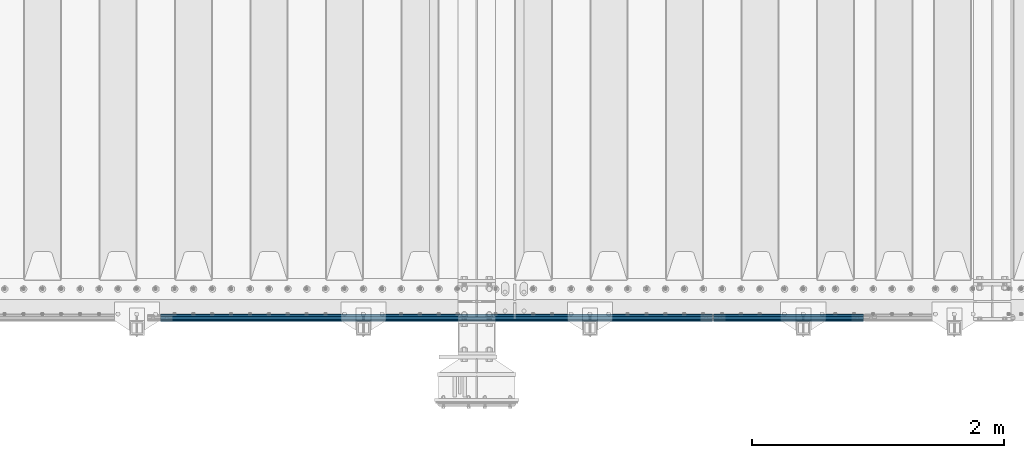
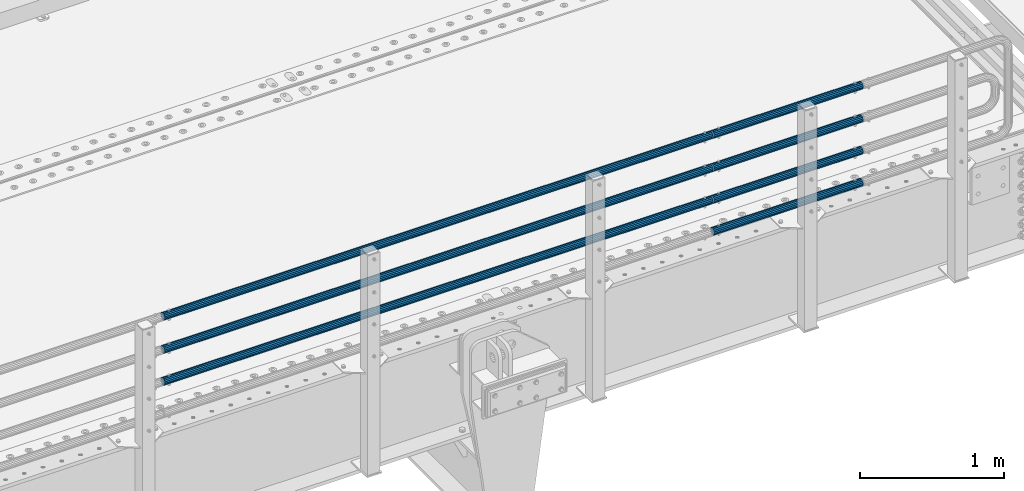
# One storey, part 100 of 208: 7 beams.
"""IFC2X3 building model written with IfcOpenShell, lengths in millimetres."""

from ifc_helpers import new_model, si_unit, frame, origin_with_axes, place, context, subcontext, project, spatial, faceted_brep, material, type_object, element, save


model = new_model("IFC2X3")

# Units and contexts
model_context = context("Model", 3, precision=1e-05, world=origin_with_axes())
body_context = subcontext(model_context, "Body", "Model", "MODEL_VIEW")
ifc_project = project(units=[si_unit("LENGTHUNIT", "METRE", prefix="MILLI"), si_unit("AREAUNIT", "SQUARE_METRE"), si_unit("VOLUMEUNIT", "CUBIC_METRE"), si_unit("MASSUNIT", "GRAM", prefix="KILO"), si_unit("TIMEUNIT", "SECOND"), si_unit("PLANEANGLEUNIT", "RADIAN"), si_unit("SOLIDANGLEUNIT", "STERADIAN"), si_unit("THERMODYNAMICTEMPERATUREUNIT", "DEGREE_CELSIUS"), si_unit("LUMINOUSINTENSITYUNIT", "LUMEN")], contexts=[model_context])

# Site, building, storey
site_placement = place(None, origin_with_axes())
site = spatial("IfcSite", under=ifc_project, at=site_placement, CompositionType="ELEMENT")
building_placement = place(site_placement, origin_with_axes())
building = spatial("IfcBuilding", under=site, at=building_placement, Name="Standard", CompositionType="ELEMENT")
storey_placement = place(building_placement, origin_with_axes())
storey = spatial("IfcBuildingStorey", under=building, at=storey_placement, Name="Undefined", CompositionType="ELEMENT", Elevation=0.0)

# Beams
ifc_material = material()
beam_type = type_object("IfcBeamType", PredefinedType="NOTDEFINED")
beam_1_placement = place(storey_placement, frame((-28328.0000000001, -129.849999999805, 420.149999999728), z_axis=(0.0, 0.0, -1.0), x_axis=(-1.0, 0.0, 0.0)))
element("IfcBeam", 1, at=beam_1_placement, inside=storey, type_object=beam_type, material=ifc_material, context=body_context, shape_type="Brep", body=[
    faceted_brep([(0.0, -26.5500000000002, 0.0), (0.0, -24.5290015881747, 10.1602451292931), (4384.0, -24.5290015881747, 10.1602451292931), (4384.0, -26.5500000000002, 0.0), (0.0, -18.7736850405026, 18.7736850405028), (4384.0, -18.7736850405026, 18.7736850405028), (0.0, -10.1602451292929, 24.5290015881747), (4384.0, -10.1602451292929, 24.5290015881747), (0.0, 0.0, 26.55), (4384.0, 0.0, 26.55), (0.0, 10.1602451292929, 24.5290015881747), (4384.0, 10.1602451292929, 24.5290015881747), (0.0, 18.7736850405026, 18.7736850405028), (4384.0, 18.7736850405026, 18.7736850405028), (0.0, 24.5290015881747, 10.1602451292931), (4384.0, 24.5290015881747, 10.1602451292931), (0.0, 26.5500000000002, 0.0), (4384.0, 26.5500000000002, 0.0), (0.0, 24.5290015881747, -10.1602451292931), (4384.0, 24.5290015881747, -10.1602451292931), (0.0, 18.7736850405026, -18.7736850405028), (4384.0, 18.7736850405026, -18.7736850405028), (0.0, 10.1602451292929, -24.5290015881747), (4384.0, 10.1602451292929, -24.5290015881747), (0.0, 0.0, -26.55), (4384.0, 0.0, -26.55), (0.0, -10.1602451292929, -24.5290015881747), (4384.0, -10.1602451292929, -24.5290015881747), (0.0, -18.7736850405026, -18.7736850405028), (4384.0, -18.7736850405026, -18.7736850405028), (0.0, -24.5290015881747, -10.1602451292931), (4384.0, -24.5290015881747, -10.1602451292931), (0.0, -30.1499999999996, 0.0), (0.0, -27.8549679052148, -11.5379054858058), (4384.0, -27.8549679052148, -11.5379054858075), (4384.0, -30.1499999999996, 0.0), (0.0, -21.3192694527743, -21.3192694527752), (4384.0, -21.3192694527743, -21.3192694527744), (0.0, -11.5379054858076, -27.8549679052157), (4384.0, -11.5379054858076, -27.8549679052153), (0.0, 0.0, -30.1500000000015), (4384.0, 0.0, -30.15), (0.0, 11.5379054858076, -27.8549679052157), (4384.0, 11.5379054858076, -27.8549679052153), (0.0, 21.3192694527743, -21.3192694527752), (4384.0, 21.3192694527743, -21.3192694527744), (0.0, 27.8549679052157, -11.5379054858058), (4384.0, 27.8549679052157, -11.5379054858074), (0.0, 30.1499999999996, 0.0), (4384.0, 30.1499999999996, 0.0), (0.0, 27.8549679052157, 11.5379054858058), (4384.0, 27.8549679052157, 11.5379054858075), (0.0, 21.3192694527743, 21.3192694527752), (4384.0, 21.3192694527743, 21.3192694527744), (0.0, 11.5379054858076, 27.8549679052157), (4384.0, 11.5379054858076, 27.8549679052153), (0.0, 0.0, 30.1500000000015), (4384.0, 0.0, 30.15), (0.0, -11.5379054858076, 27.8549679052157), (4384.0, -11.5379054858076, 27.8549679052153), (0.0, -21.3192694527743, 21.3192694527752), (4384.0, -21.3192694527743, 21.3192694527744), (0.0, -27.8549679052157, 11.5379054858058), (4384.0, -27.8549679052157, 11.5379054858075)], [[[0, 1, 2, 3]], [[1, 4, 5, 2]], [[4, 6, 7, 5]], [[6, 8, 9, 7]], [[8, 10, 11, 9]], [[10, 12, 13, 11]], [[12, 14, 15, 13]], [[14, 16, 17, 15]], [[16, 18, 19, 17]], [[18, 20, 21, 19]], [[20, 22, 23, 21]], [[22, 24, 25, 23]], [[24, 26, 27, 25]], [[26, 28, 29, 27]], [[28, 30, 31, 29]], [[30, 0, 3, 31]], [[32, 33, 34, 35]], [[33, 36, 37, 34]], [[36, 38, 39, 37]], [[38, 40, 41, 39]], [[40, 42, 43, 41]], [[42, 44, 45, 43]], [[44, 46, 47, 45]], [[46, 48, 49, 47]], [[48, 50, 51, 49]], [[50, 52, 53, 51]], [[52, 54, 55, 53]], [[54, 56, 57, 55]], [[56, 58, 59, 57]], [[58, 60, 61, 59]], [[60, 62, 63, 61]], [[62, 32, 35, 63]], [[37, 39, 41, 43, 45, 47, 49, 51, 53, 55, 57, 59, 61, 63, 35, 34], [5, 7, 9, 11, 13, 15, 17, 19, 21, 23, 25, 27, 29, 31, 3, 2]], [[62, 60, 58, 56, 54, 52, 50, 48, 46, 44, 42, 40, 38, 36, 33, 32], [30, 28, 26, 24, 22, 20, 18, 16, 14, 12, 10, 8, 6, 4, 1, 0]]]),
])
beam_2_placement = place(storey_placement, frame((-28328.0000000001, -129.849999999805, 969.849999999725), z_axis=(0.0, 0.0, -1.0), x_axis=(-1.0, 0.0, 0.0)))
element("IfcBeam", 2, at=beam_2_placement, inside=storey, type_object=beam_type, material=ifc_material, context=body_context, shape_type="Brep", body=[
    faceted_brep([(0.0, -26.5500000000002, 0.0), (0.0, -24.5290015881747, 10.1602451292931), (4384.0, -24.5290015881747, 10.1602451292931), (4384.0, -26.5500000000002, 0.0), (0.0, -18.7736850405026, 18.7736850405028), (4384.0, -18.7736850405026, 18.7736850405028), (0.0, -10.1602451292929, 24.5290015881747), (4384.0, -10.1602451292929, 24.5290015881747), (0.0, 0.0, 26.55), (4384.0, 0.0, 26.55), (0.0, 10.1602451292929, 24.5290015881747), (4384.0, 10.1602451292929, 24.5290015881747), (0.0, 18.7736850405026, 18.7736850405028), (4384.0, 18.7736850405026, 18.7736850405028), (0.0, 24.5290015881747, 10.1602451292931), (4384.0, 24.5290015881747, 10.1602451292931), (0.0, 26.5500000000002, 0.0), (4384.0, 26.5500000000002, 0.0), (0.0, 24.5290015881747, -10.1602451292931), (4384.0, 24.5290015881747, -10.1602451292931), (0.0, 18.7736850405026, -18.7736850405028), (4384.0, 18.7736850405026, -18.7736850405028), (0.0, 10.1602451292929, -24.5290015881747), (4384.0, 10.1602451292929, -24.5290015881747), (0.0, 0.0, -26.55), (4384.0, 0.0, -26.55), (0.0, -10.1602451292929, -24.5290015881747), (4384.0, -10.1602451292929, -24.5290015881747), (0.0, -18.7736850405026, -18.7736850405028), (4384.0, -18.7736850405026, -18.7736850405028), (0.0, -24.5290015881747, -10.1602451292931), (4384.0, -24.5290015881747, -10.1602451292931), (0.0, -30.1499999999996, 0.0), (0.0, -27.8549679052148, -11.5379054858058), (4384.0, -27.8549679052148, -11.5379054858075), (4384.0, -30.1499999999996, 0.0), (0.0, -21.3192694527743, -21.3192694527752), (4384.0, -21.3192694527743, -21.3192694527744), (0.0, -11.5379054858076, -27.8549679052157), (4384.0, -11.5379054858076, -27.8549679052153), (0.0, 0.0, -30.1500000000015), (4384.0, 0.0, -30.15), (0.0, 11.5379054858076, -27.8549679052157), (4384.0, 11.5379054858076, -27.8549679052153), (0.0, 21.3192694527743, -21.3192694527752), (4384.0, 21.3192694527743, -21.3192694527744), (0.0, 27.8549679052157, -11.5379054858058), (4384.0, 27.8549679052157, -11.5379054858074), (0.0, 30.1499999999996, 0.0), (4384.0, 30.1499999999996, 0.0), (0.0, 27.8549679052157, 11.5379054858058), (4384.0, 27.8549679052157, 11.5379054858075), (0.0, 21.3192694527743, 21.3192694527752), (4384.0, 21.3192694527743, 21.3192694527744), (0.0, 11.5379054858076, 27.8549679052157), (4384.0, 11.5379054858076, 27.8549679052153), (0.0, 0.0, 30.1500000000015), (4384.0, 0.0, 30.15), (0.0, -11.5379054858076, 27.8549679052157), (4384.0, -11.5379054858076, 27.8549679052153), (0.0, -21.3192694527743, 21.3192694527752), (4384.0, -21.3192694527743, 21.3192694527744), (0.0, -27.8549679052157, 11.5379054858058), (4384.0, -27.8549679052157, 11.5379054858075)], [[[0, 1, 2, 3]], [[1, 4, 5, 2]], [[4, 6, 7, 5]], [[6, 8, 9, 7]], [[8, 10, 11, 9]], [[10, 12, 13, 11]], [[12, 14, 15, 13]], [[14, 16, 17, 15]], [[16, 18, 19, 17]], [[18, 20, 21, 19]], [[20, 22, 23, 21]], [[22, 24, 25, 23]], [[24, 26, 27, 25]], [[26, 28, 29, 27]], [[28, 30, 31, 29]], [[30, 0, 3, 31]], [[32, 33, 34, 35]], [[33, 36, 37, 34]], [[36, 38, 39, 37]], [[38, 40, 41, 39]], [[40, 42, 43, 41]], [[42, 44, 45, 43]], [[44, 46, 47, 45]], [[46, 48, 49, 47]], [[48, 50, 51, 49]], [[50, 52, 53, 51]], [[52, 54, 55, 53]], [[54, 56, 57, 55]], [[56, 58, 59, 57]], [[58, 60, 61, 59]], [[60, 62, 63, 61]], [[62, 32, 35, 63]], [[37, 39, 41, 43, 45, 47, 49, 51, 53, 55, 57, 59, 61, 63, 35, 34], [5, 7, 9, 11, 13, 15, 17, 19, 21, 23, 25, 27, 29, 31, 3, 2]], [[62, 60, 58, 56, 54, 52, 50, 48, 46, 44, 42, 40, 38, 36, 33, 32], [30, 28, 26, 24, 22, 20, 18, 16, 14, 12, 10, 8, 6, 4, 1, 0]]]),
])
beam_3_placement = place(storey_placement, frame((-28317.9999999999, -129.850000000402, 419.849999999725), z_axis=(0.0, -1.0, 0.0), x_axis=(1.0, 0.0, 0.0)))
element("IfcBeam", 3, at=beam_3_placement, inside=storey, type_object=beam_type, material=ifc_material, context=body_context, shape_type="Brep", body=[
    faceted_brep([(0.0, -26.5500000000002, 0.0), (0.0, -24.5290015881747, 10.1602451292931), (1190.0, -24.5290015881747, 10.1602451292929), (1190.0, -26.55, 0.0), (0.0, -18.7736850405026, 18.7736850405028), (1190.0, -18.7736850405028, 18.7736850405026), (0.0, -10.1602451292929, 24.5290015881747), (1190.0, -10.1602451292931, 24.5290015881747), (0.0, 0.0, 26.55), (1190.0, 0.0, 26.5500000000002), (0.0, 10.1602451292929, 24.5290015881747), (1190.0, 10.1602451292932, 24.5290015881747), (0.0, 18.7736850405026, 18.7736850405028), (1190.0, 18.7736850405029, 18.7736850405026), (0.0, 24.5290015881747, 10.1602451292931), (1190.0, 24.5290015881747, 10.1602451292929), (0.0, 26.5500000000002, 0.0), (1190.0, 26.55, 0.0), (0.0, 24.5290015881747, -10.1602451292931), (1190.0, 24.5290015881747, -10.1602451292929), (0.0, 18.7736850405026, -18.7736850405028), (1190.0, 18.7736850405028, -18.7736850405026), (0.0, 10.1602451292929, -24.5290015881747), (1190.0, 10.1602451292931, -24.5290015881747), (0.0, 0.0, -26.55), (1190.0, 0.0, -26.5500000000002), (0.0, -10.1602451292929, -24.5290015881747), (1190.0, -10.1602451292931, -24.5290015881747), (0.0, -18.7736850405026, -18.7736850405028), (1190.0, -18.7736850405028, -18.7736850405026), (0.0, -24.5290015881747, -10.1602451292931), (1190.0, -24.5290015881747, -10.1602451292929), (0.0, -30.1499999999996, 0.0), (0.0, -27.8549679052148, -11.5379054858058), (1190.0, -27.8549679052153, -11.5379054858076), (1190.0, -30.15, 0.0), (0.0, -21.3192694527743, -21.3192694527752), (1190.0, -21.3192694527744, -21.3192694527743), (0.0, -11.5379054858076, -27.8549679052157), (1190.0, -11.5379054858075, -27.8549679052148), (0.0, 0.0, -30.1500000000015), (1190.0, 0.0, -30.1499999999996), (0.0, 11.5379054858076, -27.8549679052157), (1190.0, 11.5379054858075, -27.8549679052148), (0.0, 21.3192694527743, -21.3192694527752), (1190.0, 21.3192694527744, -21.3192694527743), (0.0, 27.8549679052157, -11.5379054858058), (1190.0, 27.8549679052153, -11.5379054858076), (0.0, 30.1499999999996, 0.0), (1190.0, 30.15, 0.0), (0.0, 27.8549679052157, 11.5379054858058), (1190.0, 27.8549679052153, 11.5379054858076), (0.0, 21.3192694527743, 21.3192694527752), (1190.0, 21.3192694527744, 21.3192694527743), (0.0, 11.5379054858076, 27.8549679052157), (1190.0, 11.5379054858075, 27.8549679052157), (0.0, 0.0, 30.1500000000015), (1190.0, 0.0, 30.1499999999996), (0.0, -11.5379054858076, 27.8549679052157), (1190.0, -11.5379054858075, 27.8549679052157), (0.0, -21.3192694527743, 21.3192694527752), (1190.0, -21.3192694527744, 21.3192694527743), (0.0, -27.8549679052157, 11.5379054858058), (1190.0, -27.8549679052153, 11.5379054858076)], [[[0, 1, 2, 3]], [[1, 4, 5, 2]], [[4, 6, 7, 5]], [[6, 8, 9, 7]], [[8, 10, 11, 9]], [[10, 12, 13, 11]], [[12, 14, 15, 13]], [[14, 16, 17, 15]], [[16, 18, 19, 17]], [[18, 20, 21, 19]], [[20, 22, 23, 21]], [[22, 24, 25, 23]], [[24, 26, 27, 25]], [[26, 28, 29, 27]], [[28, 30, 31, 29]], [[30, 0, 3, 31]], [[32, 33, 34, 35]], [[33, 36, 37, 34]], [[36, 38, 39, 37]], [[38, 40, 41, 39]], [[40, 42, 43, 41]], [[42, 44, 45, 43]], [[44, 46, 47, 45]], [[46, 48, 49, 47]], [[48, 50, 51, 49]], [[50, 52, 53, 51]], [[52, 54, 55, 53]], [[54, 56, 57, 55]], [[56, 58, 59, 57]], [[58, 60, 61, 59]], [[60, 62, 63, 61]], [[62, 32, 35, 63]], [[37, 39, 41, 43, 45, 47, 49, 51, 53, 55, 57, 59, 61, 63, 35, 34], [5, 7, 9, 11, 13, 15, 17, 19, 21, 23, 25, 27, 29, 31, 3, 2]], [[62, 60, 58, 56, 54, 52, 50, 48, 46, 44, 42, 40, 38, 36, 33, 32], [30, 28, 26, 24, 22, 20, 18, 16, 14, 12, 10, 8, 6, 4, 1, 0]]]),
])
beam_4_placement = place(storey_placement, frame((-28317.9999999999, -129.850000000402, 149.549999999726), z_axis=(0.0, -1.0, 0.0), x_axis=(1.0, 0.0, 0.0)))
element("IfcBeam", 4, at=beam_4_placement, inside=storey, type_object=beam_type, material=ifc_material, context=body_context, shape_type="Brep", body=[
    faceted_brep([(0.0, -26.5500000000002, 0.0), (0.0, -24.5290015881747, 10.1602451292931), (1190.0, -24.5290015881747, 10.1602451292929), (1190.0, -26.55, 0.0), (0.0, -18.7736850405026, 18.7736850405028), (1190.0, -18.7736850405028, 18.7736850405026), (0.0, -10.1602451292929, 24.5290015881747), (1190.0, -10.1602451292931, 24.5290015881747), (0.0, 0.0, 26.55), (1190.0, 0.0, 26.5500000000002), (0.0, 10.1602451292929, 24.5290015881747), (1190.0, 10.1602451292932, 24.5290015881747), (0.0, 18.7736850405026, 18.7736850405028), (1190.0, 18.7736850405029, 18.7736850405026), (0.0, 24.5290015881747, 10.1602451292931), (1190.0, 24.5290015881747, 10.1602451292929), (0.0, 26.5500000000002, 0.0), (1190.0, 26.55, 0.0), (0.0, 24.5290015881747, -10.1602451292931), (1190.0, 24.5290015881747, -10.1602451292929), (0.0, 18.7736850405026, -18.7736850405028), (1190.0, 18.7736850405028, -18.7736850405026), (0.0, 10.1602451292929, -24.5290015881747), (1190.0, 10.1602451292931, -24.5290015881747), (0.0, 0.0, -26.55), (1190.0, 0.0, -26.5500000000002), (0.0, -10.1602451292929, -24.5290015881747), (1190.0, -10.1602451292931, -24.5290015881747), (0.0, -18.7736850405026, -18.7736850405028), (1190.0, -18.7736850405028, -18.7736850405026), (0.0, -24.5290015881747, -10.1602451292931), (1190.0, -24.5290015881747, -10.1602451292929), (0.0, -30.1499999999996, 0.0), (0.0, -27.8549679052148, -11.5379054858058), (1190.0, -27.8549679052153, -11.5379054858076), (1190.0, -30.15, 0.0), (0.0, -21.3192694527743, -21.3192694527752), (1190.0, -21.3192694527744, -21.3192694527743), (0.0, -11.5379054858076, -27.8549679052157), (1190.0, -11.5379054858075, -27.8549679052148), (0.0, 0.0, -30.1500000000015), (1190.0, 0.0, -30.1499999999996), (0.0, 11.5379054858076, -27.8549679052157), (1190.0, 11.5379054858075, -27.8549679052148), (0.0, 21.3192694527743, -21.3192694527752), (1190.0, 21.3192694527744, -21.3192694527743), (0.0, 27.8549679052157, -11.5379054858058), (1190.0, 27.8549679052153, -11.5379054858076), (0.0, 30.1499999999996, 0.0), (1190.0, 30.15, 0.0), (0.0, 27.8549679052157, 11.5379054858058), (1190.0, 27.8549679052153, 11.5379054858076), (0.0, 21.3192694527743, 21.3192694527752), (1190.0, 21.3192694527744, 21.3192694527743), (0.0, 11.5379054858076, 27.8549679052157), (1190.0, 11.5379054858075, 27.8549679052157), (0.0, 0.0, 30.1500000000015), (1190.0, 0.0, 30.1499999999996), (0.0, -11.5379054858076, 27.8549679052157), (1190.0, -11.5379054858075, 27.8549679052157), (0.0, -21.3192694527743, 21.3192694527752), (1190.0, -21.3192694527744, 21.3192694527743), (0.0, -27.8549679052157, 11.5379054858058), (1190.0, -27.8549679052153, 11.5379054858076)], [[[0, 1, 2, 3]], [[1, 4, 5, 2]], [[4, 6, 7, 5]], [[6, 8, 9, 7]], [[8, 10, 11, 9]], [[10, 12, 13, 11]], [[12, 14, 15, 13]], [[14, 16, 17, 15]], [[16, 18, 19, 17]], [[18, 20, 21, 19]], [[20, 22, 23, 21]], [[22, 24, 25, 23]], [[24, 26, 27, 25]], [[26, 28, 29, 27]], [[28, 30, 31, 29]], [[30, 0, 3, 31]], [[32, 33, 34, 35]], [[33, 36, 37, 34]], [[36, 38, 39, 37]], [[38, 40, 41, 39]], [[40, 42, 43, 41]], [[42, 44, 45, 43]], [[44, 46, 47, 45]], [[46, 48, 49, 47]], [[48, 50, 51, 49]], [[50, 52, 53, 51]], [[52, 54, 55, 53]], [[54, 56, 57, 55]], [[56, 58, 59, 57]], [[58, 60, 61, 59]], [[60, 62, 63, 61]], [[62, 32, 35, 63]], [[37, 39, 41, 43, 45, 47, 49, 51, 53, 55, 57, 59, 61, 63, 35, 34], [5, 7, 9, 11, 13, 15, 17, 19, 21, 23, 25, 27, 29, 31, 3, 2]], [[62, 60, 58, 56, 54, 52, 50, 48, 46, 44, 42, 40, 38, 36, 33, 32], [30, 28, 26, 24, 22, 20, 18, 16, 14, 12, 10, 8, 6, 4, 1, 0]]]),
])
beam_5_placement = place(storey_placement, frame((-28317.9999999999, -129.850000000402, 969.549999999726), z_axis=(0.0, -1.0, 0.0), x_axis=(1.0, 0.0, 0.0)))
element("IfcBeam", 5, at=beam_5_placement, inside=storey, type_object=beam_type, material=ifc_material, context=body_context, shape_type="Brep", body=[
    faceted_brep([(0.0, -26.5500000000002, 0.0), (0.0, -24.5290015881747, 10.1602451292931), (1190.0, -24.5290015881747, 10.1602451292929), (1190.0, -26.55, 0.0), (0.0, -18.7736850405026, 18.7736850405028), (1190.0, -18.7736850405028, 18.7736850405026), (0.0, -10.1602451292929, 24.5290015881747), (1190.0, -10.1602451292931, 24.5290015881747), (0.0, 0.0, 26.55), (1190.0, 0.0, 26.5500000000002), (0.0, 10.1602451292929, 24.5290015881747), (1190.0, 10.1602451292932, 24.5290015881747), (0.0, 18.7736850405026, 18.7736850405028), (1190.0, 18.7736850405029, 18.7736850405026), (0.0, 24.5290015881747, 10.1602451292931), (1190.0, 24.5290015881747, 10.1602451292929), (0.0, 26.5500000000002, 0.0), (1190.0, 26.55, 0.0), (0.0, 24.5290015881747, -10.1602451292931), (1190.0, 24.5290015881747, -10.1602451292929), (0.0, 18.7736850405026, -18.7736850405028), (1190.0, 18.7736850405028, -18.7736850405026), (0.0, 10.1602451292929, -24.5290015881747), (1190.0, 10.1602451292931, -24.5290015881747), (0.0, 0.0, -26.55), (1190.0, 0.0, -26.5500000000002), (0.0, -10.1602451292929, -24.5290015881747), (1190.0, -10.1602451292931, -24.5290015881747), (0.0, -18.7736850405026, -18.7736850405028), (1190.0, -18.7736850405028, -18.7736850405026), (0.0, -24.5290015881747, -10.1602451292931), (1190.0, -24.5290015881747, -10.1602451292929), (0.0, -30.1499999999996, 0.0), (0.0, -27.8549679052148, -11.5379054858058), (1190.0, -27.8549679052153, -11.5379054858076), (1190.0, -30.15, 0.0), (0.0, -21.3192694527743, -21.3192694527752), (1190.0, -21.3192694527744, -21.3192694527743), (0.0, -11.5379054858076, -27.8549679052157), (1190.0, -11.5379054858075, -27.8549679052148), (0.0, 0.0, -30.1500000000015), (1190.0, 0.0, -30.1499999999996), (0.0, 11.5379054858076, -27.8549679052157), (1190.0, 11.5379054858075, -27.8549679052148), (0.0, 21.3192694527743, -21.3192694527752), (1190.0, 21.3192694527744, -21.3192694527743), (0.0, 27.8549679052157, -11.5379054858058), (1190.0, 27.8549679052153, -11.5379054858076), (0.0, 30.1499999999996, 0.0), (1190.0, 30.15, 0.0), (0.0, 27.8549679052157, 11.5379054858058), (1190.0, 27.8549679052153, 11.5379054858076), (0.0, 21.3192694527743, 21.3192694527752), (1190.0, 21.3192694527744, 21.3192694527743), (0.0, 11.5379054858076, 27.8549679052157), (1190.0, 11.5379054858075, 27.8549679052157), (0.0, 0.0, 30.1500000000015), (1190.0, 0.0, 30.1499999999996), (0.0, -11.5379054858076, 27.8549679052157), (1190.0, -11.5379054858075, 27.8549679052157), (0.0, -21.3192694527743, 21.3192694527752), (1190.0, -21.3192694527744, 21.3192694527743), (0.0, -27.8549679052157, 11.5379054858058), (1190.0, -27.8549679052153, 11.5379054858076)], [[[0, 1, 2, 3]], [[1, 4, 5, 2]], [[4, 6, 7, 5]], [[6, 8, 9, 7]], [[8, 10, 11, 9]], [[10, 12, 13, 11]], [[12, 14, 15, 13]], [[14, 16, 17, 15]], [[16, 18, 19, 17]], [[18, 20, 21, 19]], [[20, 22, 23, 21]], [[22, 24, 25, 23]], [[24, 26, 27, 25]], [[26, 28, 29, 27]], [[28, 30, 31, 29]], [[30, 0, 3, 31]], [[32, 33, 34, 35]], [[33, 36, 37, 34]], [[36, 38, 39, 37]], [[38, 40, 41, 39]], [[40, 42, 43, 41]], [[42, 44, 45, 43]], [[44, 46, 47, 45]], [[46, 48, 49, 47]], [[48, 50, 51, 49]], [[50, 52, 53, 51]], [[52, 54, 55, 53]], [[54, 56, 57, 55]], [[56, 58, 59, 57]], [[58, 60, 61, 59]], [[60, 62, 63, 61]], [[62, 32, 35, 63]], [[37, 39, 41, 43, 45, 47, 49, 51, 53, 55, 57, 59, 61, 63, 35, 34], [5, 7, 9, 11, 13, 15, 17, 19, 21, 23, 25, 27, 29, 31, 3, 2]], [[62, 60, 58, 56, 54, 52, 50, 48, 46, 44, 42, 40, 38, 36, 33, 32], [30, 28, 26, 24, 22, 20, 18, 16, 14, 12, 10, 8, 6, 4, 1, 0]]]),
])
beam_6_placement = place(storey_placement, frame((-28317.9999999999, -129.850000000402, 689.549999999726), z_axis=(0.0, -1.0, 0.0), x_axis=(1.0, 0.0, 0.0)))
element("IfcBeam", 6, at=beam_6_placement, inside=storey, type_object=beam_type, material=ifc_material, context=body_context, shape_type="Brep", body=[
    faceted_brep([(0.0, -26.5500000000002, 0.0), (0.0, -24.5290015881747, 10.1602451292931), (1190.0, -24.5290015881747, 10.1602451292929), (1190.0, -26.55, 0.0), (0.0, -18.7736850405026, 18.7736850405028), (1190.0, -18.7736850405028, 18.7736850405026), (0.0, -10.1602451292929, 24.5290015881747), (1190.0, -10.1602451292931, 24.5290015881747), (0.0, 0.0, 26.55), (1190.0, 0.0, 26.5500000000002), (0.0, 10.1602451292929, 24.5290015881747), (1190.0, 10.1602451292932, 24.5290015881747), (0.0, 18.7736850405026, 18.7736850405028), (1190.0, 18.7736850405029, 18.7736850405026), (0.0, 24.5290015881747, 10.1602451292931), (1190.0, 24.5290015881747, 10.1602451292929), (0.0, 26.5500000000002, 0.0), (1190.0, 26.55, 0.0), (0.0, 24.5290015881747, -10.1602451292931), (1190.0, 24.5290015881747, -10.1602451292929), (0.0, 18.7736850405026, -18.7736850405028), (1190.0, 18.7736850405028, -18.7736850405026), (0.0, 10.1602451292929, -24.5290015881747), (1190.0, 10.1602451292931, -24.5290015881747), (0.0, 0.0, -26.55), (1190.0, 0.0, -26.5500000000002), (0.0, -10.1602451292929, -24.5290015881747), (1190.0, -10.1602451292931, -24.5290015881747), (0.0, -18.7736850405026, -18.7736850405028), (1190.0, -18.7736850405028, -18.7736850405026), (0.0, -24.5290015881747, -10.1602451292931), (1190.0, -24.5290015881747, -10.1602451292929), (0.0, -30.1499999999996, 0.0), (0.0, -27.8549679052148, -11.5379054858058), (1190.0, -27.8549679052153, -11.5379054858076), (1190.0, -30.15, 0.0), (0.0, -21.3192694527743, -21.3192694527752), (1190.0, -21.3192694527744, -21.3192694527743), (0.0, -11.5379054858076, -27.8549679052157), (1190.0, -11.5379054858075, -27.8549679052148), (0.0, 0.0, -30.1500000000015), (1190.0, 0.0, -30.1499999999996), (0.0, 11.5379054858076, -27.8549679052157), (1190.0, 11.5379054858075, -27.8549679052148), (0.0, 21.3192694527743, -21.3192694527752), (1190.0, 21.3192694527744, -21.3192694527743), (0.0, 27.8549679052157, -11.5379054858058), (1190.0, 27.8549679052153, -11.5379054858076), (0.0, 30.1499999999996, 0.0), (1190.0, 30.15, 0.0), (0.0, 27.8549679052157, 11.5379054858058), (1190.0, 27.8549679052153, 11.5379054858076), (0.0, 21.3192694527743, 21.3192694527752), (1190.0, 21.3192694527744, 21.3192694527743), (0.0, 11.5379054858076, 27.8549679052157), (1190.0, 11.5379054858075, 27.8549679052157), (0.0, 0.0, 30.1500000000015), (1190.0, 0.0, 30.1499999999996), (0.0, -11.5379054858076, 27.8549679052157), (1190.0, -11.5379054858075, 27.8549679052157), (0.0, -21.3192694527743, 21.3192694527752), (1190.0, -21.3192694527744, 21.3192694527743), (0.0, -27.8549679052157, 11.5379054858058), (1190.0, -27.8549679052153, 11.5379054858076)], [[[0, 1, 2, 3]], [[1, 4, 5, 2]], [[4, 6, 7, 5]], [[6, 8, 9, 7]], [[8, 10, 11, 9]], [[10, 12, 13, 11]], [[12, 14, 15, 13]], [[14, 16, 17, 15]], [[16, 18, 19, 17]], [[18, 20, 21, 19]], [[20, 22, 23, 21]], [[22, 24, 25, 23]], [[24, 26, 27, 25]], [[26, 28, 29, 27]], [[28, 30, 31, 29]], [[30, 0, 3, 31]], [[32, 33, 34, 35]], [[33, 36, 37, 34]], [[36, 38, 39, 37]], [[38, 40, 41, 39]], [[40, 42, 43, 41]], [[42, 44, 45, 43]], [[44, 46, 47, 45]], [[46, 48, 49, 47]], [[48, 50, 51, 49]], [[50, 52, 53, 51]], [[52, 54, 55, 53]], [[54, 56, 57, 55]], [[56, 58, 59, 57]], [[58, 60, 61, 59]], [[60, 62, 63, 61]], [[62, 32, 35, 63]], [[37, 39, 41, 43, 45, 47, 49, 51, 53, 55, 57, 59, 61, 63, 35, 34], [5, 7, 9, 11, 13, 15, 17, 19, 21, 23, 25, 27, 29, 31, 3, 2]], [[62, 60, 58, 56, 54, 52, 50, 48, 46, 44, 42, 40, 38, 36, 33, 32], [30, 28, 26, 24, 22, 20, 18, 16, 14, 12, 10, 8, 6, 4, 1, 0]]]),
])
beam_7_placement = place(storey_placement, frame((-28328.0000000001, -129.849999999805, 689.849999999725), z_axis=(0.0, 0.0, -1.0), x_axis=(-1.0, 0.0, 0.0)))
element("IfcBeam", 7, at=beam_7_placement, inside=storey, type_object=beam_type, material=ifc_material, context=body_context, shape_type="Brep", body=[
    faceted_brep([(0.0, -26.5500000000002, 0.0), (0.0, -24.5290015881747, 10.1602451292931), (4384.0, -24.5290015881747, 10.1602451292931), (4384.0, -26.5500000000002, 0.0), (0.0, -18.7736850405026, 18.7736850405028), (4384.0, -18.7736850405026, 18.7736850405028), (0.0, -10.1602451292929, 24.5290015881747), (4384.0, -10.1602451292929, 24.5290015881747), (0.0, 0.0, 26.55), (4384.0, 0.0, 26.55), (0.0, 10.1602451292929, 24.5290015881747), (4384.0, 10.1602451292929, 24.5290015881747), (0.0, 18.7736850405026, 18.7736850405028), (4384.0, 18.7736850405026, 18.7736850405028), (0.0, 24.5290015881747, 10.1602451292931), (4384.0, 24.5290015881747, 10.1602451292931), (0.0, 26.5500000000002, 0.0), (4384.0, 26.5500000000002, 0.0), (0.0, 24.5290015881747, -10.1602451292931), (4384.0, 24.5290015881747, -10.1602451292931), (0.0, 18.7736850405026, -18.7736850405028), (4384.0, 18.7736850405026, -18.7736850405028), (0.0, 10.1602451292929, -24.5290015881747), (4384.0, 10.1602451292929, -24.5290015881747), (0.0, 0.0, -26.55), (4384.0, 0.0, -26.55), (0.0, -10.1602451292929, -24.5290015881747), (4384.0, -10.1602451292929, -24.5290015881747), (0.0, -18.7736850405026, -18.7736850405028), (4384.0, -18.7736850405026, -18.7736850405028), (0.0, -24.5290015881747, -10.1602451292931), (4384.0, -24.5290015881747, -10.1602451292931), (0.0, -30.1499999999996, 0.0), (0.0, -27.8549679052148, -11.5379054858058), (4384.0, -27.8549679052148, -11.5379054858075), (4384.0, -30.1499999999996, 0.0), (0.0, -21.3192694527743, -21.3192694527752), (4384.0, -21.3192694527743, -21.3192694527744), (0.0, -11.5379054858076, -27.8549679052157), (4384.0, -11.5379054858076, -27.8549679052153), (0.0, 0.0, -30.1500000000015), (4384.0, 0.0, -30.15), (0.0, 11.5379054858076, -27.8549679052157), (4384.0, 11.5379054858076, -27.8549679052153), (0.0, 21.3192694527743, -21.3192694527752), (4384.0, 21.3192694527743, -21.3192694527744), (0.0, 27.8549679052157, -11.5379054858058), (4384.0, 27.8549679052157, -11.5379054858074), (0.0, 30.1499999999996, 0.0), (4384.0, 30.1499999999996, 0.0), (0.0, 27.8549679052157, 11.5379054858058), (4384.0, 27.8549679052157, 11.5379054858075), (0.0, 21.3192694527743, 21.3192694527752), (4384.0, 21.3192694527743, 21.3192694527744), (0.0, 11.5379054858076, 27.8549679052157), (4384.0, 11.5379054858076, 27.8549679052153), (0.0, 0.0, 30.1500000000015), (4384.0, 0.0, 30.15), (0.0, -11.5379054858076, 27.8549679052157), (4384.0, -11.5379054858076, 27.8549679052153), (0.0, -21.3192694527743, 21.3192694527752), (4384.0, -21.3192694527743, 21.3192694527744), (0.0, -27.8549679052157, 11.5379054858058), (4384.0, -27.8549679052157, 11.5379054858075)], [[[0, 1, 2, 3]], [[1, 4, 5, 2]], [[4, 6, 7, 5]], [[6, 8, 9, 7]], [[8, 10, 11, 9]], [[10, 12, 13, 11]], [[12, 14, 15, 13]], [[14, 16, 17, 15]], [[16, 18, 19, 17]], [[18, 20, 21, 19]], [[20, 22, 23, 21]], [[22, 24, 25, 23]], [[24, 26, 27, 25]], [[26, 28, 29, 27]], [[28, 30, 31, 29]], [[30, 0, 3, 31]], [[32, 33, 34, 35]], [[33, 36, 37, 34]], [[36, 38, 39, 37]], [[38, 40, 41, 39]], [[40, 42, 43, 41]], [[42, 44, 45, 43]], [[44, 46, 47, 45]], [[46, 48, 49, 47]], [[48, 50, 51, 49]], [[50, 52, 53, 51]], [[52, 54, 55, 53]], [[54, 56, 57, 55]], [[56, 58, 59, 57]], [[58, 60, 61, 59]], [[60, 62, 63, 61]], [[62, 32, 35, 63]], [[37, 39, 41, 43, 45, 47, 49, 51, 53, 55, 57, 59, 61, 63, 35, 34], [5, 7, 9, 11, 13, 15, 17, 19, 21, 23, 25, 27, 29, 31, 3, 2]], [[62, 60, 58, 56, 54, 52, 50, 48, 46, 44, 42, 40, 38, 36, 33, 32], [30, 28, 26, 24, 22, 20, 18, 16, 14, 12, 10, 8, 6, 4, 1, 0]]]),
])

save(model, "model.ifc")
